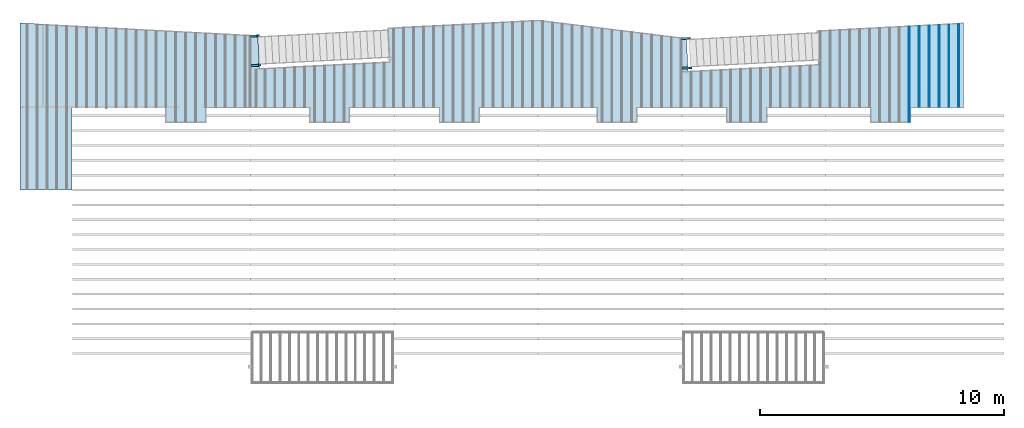
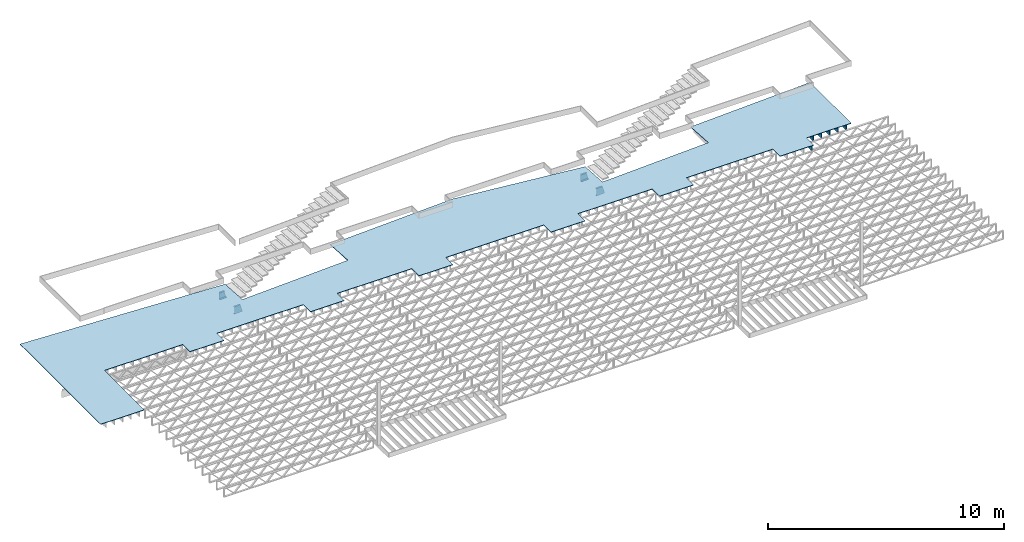
# One storey, part 13 of 23: 10 beams, 1 slab, 1 element without a shape of its own.
"""IFC4 building model written with IfcOpenShell, lengths in feet."""

from ifc_helpers import new_model, entity, si_unit, converted_unit, derived_unit, direction, frame, frame_2d, origin, origin_2d_with_axis, place, context, subcontext, project, spatial, polyline, circle_curve, parameter, trimmed, segment, composite_curve, rectangle, outline, extrude, clip, halfspace, source, transform, mapped, material, layer, layer_set, layer_usage, material_profile, profile_set, profile_usage, type_object, type_shapes, element, aggregate, save


model = new_model("IFC4")

# Units and contexts
model_context_1 = context("Model", 3, precision=0.0001, world=origin(), true_north=direction((6.12303176911189e-17, 1.0)))
model_context_2 = context("Model", 3, precision=0.0001, world=origin(), true_north=direction((6.12303176911189e-17, 1.0)))
body_context = subcontext(model_context_2, "Body", "Model", "MODEL_VIEW")
ifc_project = project(units=[converted_unit("LENGTHUNIT", "FOOT", entity("IfcRatioMeasure", 0.3048), si_unit("LENGTHUNIT", "METRE"), dimensions=[1, 0, 0, 0, 0, 0, 0]), converted_unit("AREAUNIT", "SQUARE FOOT", entity("IfcRatioMeasure", 0.09290304), si_unit("AREAUNIT", "SQUARE_METRE"), dimensions=[2, 0, 0, 0, 0, 0, 0]), converted_unit("VOLUMEUNIT", "CUBIC FOOT", entity("IfcRatioMeasure", 0.028316846592), si_unit("VOLUMEUNIT", "CUBIC_METRE"), dimensions=[3, 0, 0, 0, 0, 0, 0]), converted_unit("PLANEANGLEUNIT", "DEGREE", entity("IfcRatioMeasure", 0.0174532925199433), si_unit("PLANEANGLEUNIT", "RADIAN"), dimensions=[0, 0, 0, 0, 0, 0, 0]), si_unit("MASSUNIT", "GRAM", prefix="KILO"), derived_unit("MASSDENSITYUNIT", [(si_unit("MASSUNIT", "GRAM", prefix="KILO"), 1), (si_unit("LENGTHUNIT", "METRE"), -3)]), derived_unit("MOMENTOFINERTIAUNIT", [(si_unit("LENGTHUNIT", "METRE"), 4)]), si_unit("TIMEUNIT", "SECOND"), si_unit("FREQUENCYUNIT", "HERTZ"), si_unit("THERMODYNAMICTEMPERATUREUNIT", "DEGREE_CELSIUS"), derived_unit("THERMALTRANSMITTANCEUNIT", [(si_unit("MASSUNIT", "GRAM", prefix="KILO"), 1), (si_unit("THERMODYNAMICTEMPERATUREUNIT", "KELVIN"), -1), (si_unit("TIMEUNIT", "SECOND"), -3)]), derived_unit("VOLUMETRICFLOWRATEUNIT", [(si_unit("LENGTHUNIT", "METRE"), 3), (si_unit("TIMEUNIT", "SECOND"), -1)]), si_unit("ELECTRICCURRENTUNIT", "AMPERE"), si_unit("ELECTRICVOLTAGEUNIT", "VOLT"), si_unit("POWERUNIT", "WATT"), si_unit("FORCEUNIT", "NEWTON"), si_unit("ILLUMINANCEUNIT", "LUX"), si_unit("LUMINOUSFLUXUNIT", "LUMEN"), si_unit("LUMINOUSINTENSITYUNIT", "CANDELA"), derived_unit("USERDEFINED", [(si_unit("MASSUNIT", "GRAM", prefix="KILO"), -1), (si_unit("LENGTHUNIT", "METRE"), -2), (si_unit("TIMEUNIT", "SECOND"), 3), (si_unit("LUMINOUSFLUXUNIT", "LUMEN"), 1)]), derived_unit("LINEARVELOCITYUNIT", [(si_unit("LENGTHUNIT", "METRE"), 1), (si_unit("TIMEUNIT", "SECOND"), -1)]), si_unit("PRESSUREUNIT", "PASCAL"), derived_unit("USERDEFINED", [(si_unit("LENGTHUNIT", "METRE"), -2), (si_unit("MASSUNIT", "GRAM", prefix="KILO"), 1), (si_unit("TIMEUNIT", "SECOND"), -2)]), derived_unit("LINEARFORCEUNIT", [(si_unit("MASSUNIT", "GRAM", prefix="KILO"), 1), (si_unit("LENGTHUNIT", "METRE"), 1), (si_unit("TIMEUNIT", "SECOND"), -2), (si_unit("LENGTHUNIT", "METRE"), -1)]), derived_unit("PLANARFORCEUNIT", [(si_unit("MASSUNIT", "GRAM", prefix="KILO"), 1), (si_unit("LENGTHUNIT", "METRE"), 1), (si_unit("TIMEUNIT", "SECOND"), -2), (si_unit("LENGTHUNIT", "METRE"), -2)])], contexts=[model_context_1])

# Site, building, storey
site_placement = place(None, origin())
site = spatial("IfcSite", under=ifc_project, at=site_placement, CompositionType="ELEMENT")
building_placement = place(site_placement, origin())
building = spatial("IfcBuilding", under=site, at=building_placement, CompositionType="ELEMENT")
storey_placement = place(building_placement, frame((0.0, 0.0, 10.8020833333333)))
storey = spatial("IfcBuildingStorey", under=building, at=storey_placement, Name="2ND FLOOR", CompositionType="ELEMENT", Elevation=10.8020833333333)

# Assembly, beam
assembly_placement = place(storey_placement, origin())
assembly = element("IfcElementAssembly", 1, at=assembly_placement, inside=storey, Name="Structural Beam System:Structural Framing System", ObjectType="Structural Beam System:Structural Framing System", AssemblyPlace="NOTDEFINED", PredefinedType="BEAM_GRID")
ifc_material_1 = material(Category="Materials")
ifc_material_profile_1 = material_profile(ifc_material_1, rectangle(XDim=0.9375, YDim=0.125000000000011, at=origin_2d_with_axis()))
ifc_profile_set_1 = profile_set([ifc_material_profile_1])
ifc_profile_usage_1 = profile_usage(ifc_profile_set_1, cardinal=8)
beam_type_1 = type_object("IfcBeamType", PredefinedType="BEAM", material=ifc_profile_set_1)
shared_shape_1 = source(origin(), body_context, "Body", "SweptSolid", [
    extrude(rectangle(XDim=0.9375, YDim=0.125000000000011, at=origin_2d_with_axis()), frame((-5.50563608775167, 0.0, 0.0), z_axis=(1.0, 0.0, 0.0), x_axis=(0.0, 0.0, -1.0)), (0.0, 0.0, 1.0), 11.0112721755033),
])
type_shapes(beam_type_1, [shared_shape_1])
beam_1_placement = place(assembly_placement, frame((-149.133993818795, 964.544654780593, -0.729166666666744), z_axis=(0.0, 0.0, 1.0), x_axis=(0.0, 1.0, 0.0)))
beam_1 = element("IfcBeam", 2, at=beam_1_placement, type_object=beam_type_1, material=ifc_profile_usage_1, PredefinedType="BEAM", context=body_context, shape_type="MappedRepresentation", body=[
    mapped(shared_shape_1, transform((0.0, 0.0, 0.0), scale=1.0)),
])

# Beams
ifc_material_2 = material(Name="STEEL C CHANNEL - HDG - SEE STRUCT", Category="Materials")
ifc_material_profile_2 = material_profile(ifc_material_2, outline(composite_curve([segment(polyline([(-0.625000000000096, -0.136458333333336), (0.625000000000011, -0.136458333333336)]), True, "CONTINUOUS"), segment(polyline([(0.625000000000011, -0.136458333333336), (0.625000000000011, 0.14687499999997)]), True, "CONTINUOUS"), segment(trimmed(circle_curve(frame_2d((0.624999999999954, 0.0927083333333472), x_axis=(0.0, 1.0)), 0.054166666666607), [parameter(0.0)], [parameter(90.0000000000565)], True, "PARAMETER"), True, "CONTINUOUS"), segment(polyline([(0.570833333333347, 0.0927083333333473), (0.539816380436459, -0.1031250000001)]), True, "CONTINUOUS"), segment(polyline([(0.539816380436459, -0.103124999999986), (-0.539816380436541, -0.103124999999985)]), True, "CONTINUOUS"), segment(polyline([(-0.539816380436431, -0.103124999999985), (-0.570833333333319, 0.0927083333333486)]), True, "CONTINUOUS"), segment(trimmed(circle_curve(frame_2d((-0.624999999999922, 0.0927083333333487), x_axis=(1.0, 0.0)), 0.0541666666665973), [parameter(0.0)], [parameter(90.0000000001767)], True, "PARAMETER"), True, "CONTINUOUS"), segment(polyline([(-0.624999999999989, 0.14687499999997), (-0.624999999999986, -0.136458333333336)]), True, "CONTINUOUS")], self_intersect=False)), Name="C15x33.9, TYP. STRINGER")
ifc_profile_set_2 = profile_set([ifc_material_profile_2], Name="C15x33.9, TYP. STRINGER")
ifc_profile_usage_2 = profile_usage(ifc_profile_set_2, cardinal=8)
beam_type_2 = type_object("IfcBeamType", Name="C-Channel:C15x33.9, TYP. STRINGER", PredefinedType="BEAM", material=ifc_profile_set_2)
shared_shape_2 = source(origin(), body_context, "Body", "Clipping", [
    clip(extrude(outline(composite_curve([segment(polyline([(-0.146875000000084, -0.624999999999993), (0.136458333333448, -0.624999999999993)]), True, "CONTINUOUS"), segment(polyline([(0.13645833333322, -0.625000000000076), (0.136458333333333, 0.625000000000007)]), True, "CONTINUOUS"), segment(polyline([(0.136458333333448, 0.625000000000007), (-0.146874999999971, 0.625000000000007)]), True, "CONTINUOUS"), segment(trimmed(circle_curve(frame_2d((-0.0927083333334615, 0.624999999999929), x_axis=(-1.0, 0.0)), 0.0541666666665845), [parameter(0.0)], [parameter(90.0000000002029)], True, "PARAMETER"), True, "CONTINUOUS"), segment(polyline([(-0.0927083333334615, 0.570833333333338), (0.103124999999984, 0.539816380436438)]), True, "CONTINUOUS"), segment(polyline([(0.10312499999987, 0.539816380436449), (0.10312499999987, -0.539816380436518)]), True, "CONTINUOUS"), segment(polyline([(0.103125000000098, -0.539816380436406), (-0.0927083333334615, -0.570833333333331)]), True, "CONTINUOUS"), segment(trimmed(circle_curve(frame_2d((-0.092708333333575, -0.62499999999987), x_axis=(0.0, 1.0)), 0.0541666666665441), [parameter(0.0)], [parameter(90.0000000005389)], True, "PARAMETER"), True, "CONTINUOUS")], self_intersect=False)), frame((-241.721090693233, 964.591043315299, 8.97916666666633), z_axis=(0.99862953475458, 0.0523359562428374, 0.0), x_axis=(0.0523359562428374, -0.99862953475458, 0.0)), (0.0, 0.0, 1.0), 1.35148027803678), halfspace(frame((-240.034458951307, 965.538675935652, 6.99303841413297), z_axis=(0.961401963826961, 0.0503849419223695, 0.270495141503766), x_axis=(0.270124437313279, 0.0141566218896707, -0.962721339964404)), False)),
])
type_shapes(beam_type_2, [shared_shape_2])
beam_2_placement = place(storey_placement, frame((0.0, 0.0, -10.8020833333333)))
element("IfcBeam", 3, at=beam_2_placement, inside=storey, type_object=beam_type_2, material=ifc_profile_usage_2, Name="C-Channel:C15x33.9, TYP. STRINGER", ObjectType="C-Channel:C15x33.9, TYP. STRINGER", PredefinedType="BEAM", context=body_context, shape_type="MappedRepresentation", body=[
    mapped(shared_shape_2, transform((0.0, 0.0, 0.0), scale=1.0)),
])
ifc_profile_usage_3 = profile_usage(ifc_profile_set_2, cardinal=8)
beam_type_3 = type_object("IfcBeamType", Name="C-Channel:C15x33.9, TYP. STRINGER", PredefinedType="BEAM", material=ifc_profile_set_2)
shared_shape_3 = source(origin(), body_context, "Body", "Clipping", [
    clip(clip(extrude(outline(composite_curve([segment(polyline([(-0.625000000000227, -0.136458333333221), (0.625000000000027, -0.136458333333221)]), True, "CONTINUOUS"), segment(polyline([(0.625000000000027, -0.136458333333221), (0.625000000000027, 0.146875000000426)]), True, "CONTINUOUS"), segment(trimmed(circle_curve(frame_2d((0.624999999999968, 0.0927083333334622), x_axis=(0.0, 1.0)), 0.0541666666666086), [parameter(0.0)], [parameter(90.0000000000584)], True, "PARAMETER"), True, "CONTINUOUS"), segment(polyline([(0.570833333333399, 0.0927083333336894), (0.539816380436473, -0.103124999999871)]), True, "CONTINUOUS"), segment(polyline([(0.539816380436475, -0.103124999999871), (-0.539816380436669, -0.10312499999987)]), True, "CONTINUOUS"), segment(polyline([(-0.539816380436415, -0.10312499999987), (-0.570833333333322, 0.0927083333335772)]), True, "CONTINUOUS"), segment(trimmed(circle_curve(frame_2d((-0.62499999999992, 0.0927083333334637), x_axis=(1.0, 0.0)), 0.0541666666666016), [parameter(0.0)], [parameter(90.0000000003082)], True, "PARAMETER"), True, "CONTINUOUS"), segment(polyline([(-0.624999999999973, 0.1468750000002), (-0.624999999999973, -0.136458333333221)]), True, "CONTINUOUS")], self_intersect=False)), frame((-241.745847329124, 968.572287142718, 8.97916666667323), z_axis=(0.998629534754581, 0.0523359562428164, 0.0), x_axis=(0.0, 0.0, 1.0)), (0.0, 0.0, 1.0), 1.16784078307327), halfspace(frame((-241.738160485591, 933.741866098016, 4.0), z_axis=(-1.0, 0.0, 0.0), x_axis=(0.0, -1.0, 0.0)), False)), halfspace(frame((-240.034458951307, 965.538675935652, 6.99303841413297), z_axis=(0.961401963826961, 0.0503849419223695, 0.270495141503766), x_axis=(0.270124437313279, 0.0141566218896707, -0.962721339964404)), False)),
])
type_shapes(beam_type_3, [shared_shape_3])
beam_3_placement = place(storey_placement, frame((0.0, 0.0, -10.8020833333333)))
element("IfcBeam", 4, at=beam_3_placement, inside=storey, type_object=beam_type_3, material=ifc_profile_usage_3, Name="C-Channel:C15x33.9, TYP. STRINGER", ObjectType="C-Channel:C15x33.9, TYP. STRINGER", PredefinedType="BEAM", context=body_context, shape_type="MappedRepresentation", body=[
    mapped(shared_shape_3, transform((0.0, 0.0, 0.0), scale=1.0)),
])
ifc_profile_usage_4 = profile_usage(ifc_profile_set_2, cardinal=8)
beam_type_4 = type_object("IfcBeamType", Name="C-Channel:C15x33.9, TYP. STRINGER", PredefinedType="BEAM", material=ifc_profile_set_2)
shared_shape_4 = source(origin(), body_context, "Body", "Clipping", [
    clip(extrude(outline(composite_curve([segment(polyline([(-0.146875000000083, -0.624999999999993), (0.13645833333345, -0.624999999999993)]), True, "CONTINUOUS"), segment(polyline([(0.136458333333221, -0.625000000000069), (0.136458333333221, 0.625000000000007)]), True, "CONTINUOUS"), segment(polyline([(0.13645833333345, 0.625000000000007), (-0.146875000000083, 0.625000000000007)]), True, "CONTINUOUS"), segment(trimmed(circle_curve(frame_2d((-0.09270833333346, 0.624999999999929), x_axis=(-1.0, 0.0)), 0.0541666666665845), [parameter(0.0)], [parameter(90.0000000002029)], True, "PARAMETER"), True, "CONTINUOUS"), segment(polyline([(-0.09270833333346, 0.570833333333338), (0.103125000000099, 0.539816380436422)]), True, "CONTINUOUS"), segment(polyline([(0.103124999999872, 0.539816380436449), (0.103124999999872, -0.539816380436518)]), True, "CONTINUOUS"), segment(polyline([(0.103125000000099, -0.539816380436406), (-0.09270833333346, -0.570833333333329)]), True, "CONTINUOUS"), segment(trimmed(circle_curve(frame_2d((-0.0927083333335735, -0.62499999999987), x_axis=(0.0, 1.0)), 0.0541666666665439), [parameter(0.0)], [parameter(90.0000000005408)], True, "PARAMETER"), True, "CONTINUOUS")], self_intersect=False)), frame((-183.721090693233, 964.243642603455, 8.97916666665938), z_axis=(0.99862953475458, 0.0523359562428374, 0.0), x_axis=(0.0523359562428374, -0.99862953475458, 0.0)), (0.0, 0.0, 1.0), 1.35148027803877), halfspace(frame((-182.034458951307, 965.191275223808, 6.99303841413298), z_axis=(0.961401963826961, 0.0503849419223695, 0.270495141503766), x_axis=(0.270124437313279, 0.0141566218896707, -0.962721339964404)), False)),
])
type_shapes(beam_type_4, [shared_shape_4])
beam_4_placement = place(storey_placement, frame((0.0, 0.0, -10.8020833333333)))
element("IfcBeam", 5, at=beam_4_placement, inside=storey, type_object=beam_type_4, material=ifc_profile_usage_4, Name="C-Channel:C15x33.9, TYP. STRINGER", ObjectType="C-Channel:C15x33.9, TYP. STRINGER", PredefinedType="BEAM", context=body_context, shape_type="MappedRepresentation", body=[
    mapped(shared_shape_4, transform((0.0, 0.0, 0.0), scale=1.0)),
])
ifc_profile_usage_5 = profile_usage(ifc_profile_set_2, cardinal=8)
beam_type_5 = type_object("IfcBeamType", Name="C-Channel:C15x33.9, TYP. STRINGER", PredefinedType="BEAM", material=ifc_profile_set_2)
shared_shape_5 = source(origin(), body_context, "Body", "Clipping", [
    clip(extrude(outline(composite_curve([segment(polyline([(-0.625000000000226, -0.13645833333345), (0.625000000000028, -0.13645833333345)]), True, "CONTINUOUS"), segment(polyline([(0.625000000000028, -0.13645833333345), (0.625000000000028, 0.146875000000198)]), True, "CONTINUOUS"), segment(trimmed(circle_curve(frame_2d((0.62499999999997, 0.0927083333332329), x_axis=(0.0, 1.0)), 0.054166666666608), [parameter(0.0)], [parameter(90.0000000000584)], True, "PARAMETER"), True, "CONTINUOUS"), segment(polyline([(0.5708333333334, 0.0927083333334615), (0.539816380436475, -0.103125000000099)]), True, "CONTINUOUS"), segment(polyline([(0.539816380436477, -0.103125000000099), (-0.539816380436667, -0.103125000000101)]), True, "CONTINUOUS"), segment(polyline([(-0.539816380436413, -0.103125000000101), (-0.57083333333332, 0.0927083333333465)]), True, "CONTINUOUS"), segment(trimmed(circle_curve(frame_2d((-0.624999999999917, 0.0927083333332329), x_axis=(1.0, 0.0)), 0.0541666666665999), [parameter(0.0)], [parameter(90.0000000003101)], True, "PARAMETER"), True, "CONTINUOUS"), segment(polyline([(-0.624999999999972, 0.146874999999969), (-0.624999999999972, -0.13645833333345)]), True, "CONTINUOUS")], self_intersect=False)), frame((-183.827402830635, 968.220612288151, 8.97916666667324), z_axis=(0.998629534754575, 0.0523359562429165, 0.0), x_axis=(0.0, 0.0, 1.0)), (0.0, 0.0, 1.0), 1.24950820695101), halfspace(frame((-182.034458951307, 965.191275223808, 6.99303841413298), z_axis=(0.961401963826961, 0.0503849419223695, 0.270495141503766), x_axis=(0.270124437313279, 0.0141566218896707, -0.962721339964404)), False)),
])
type_shapes(beam_type_5, [shared_shape_5])
beam_5_placement = place(storey_placement, frame((0.0, 0.0, -10.8020833333333)))
element("IfcBeam", 6, at=beam_5_placement, inside=storey, type_object=beam_type_5, material=ifc_profile_usage_5, Name="C-Channel:C15x33.9, TYP. STRINGER", ObjectType="C-Channel:C15x33.9, TYP. STRINGER", PredefinedType="BEAM", context=body_context, shape_type="MappedRepresentation", body=[
    mapped(shared_shape_5, transform((0.0, 0.0, 0.0), scale=1.0)),
])

# Beam
ifc_profile_usage_6 = profile_usage(ifc_profile_set_1, cardinal=8)
beam_type_6 = type_object("IfcBeamType", PredefinedType="BEAM", material=ifc_profile_set_1)
shared_shape_6 = source(origin(), body_context, "Body", "SweptSolid", [
    extrude(rectangle(XDim=0.9375, YDim=0.125000000000011, at=origin_2d_with_axis()), frame((-6.40602910094731, 0.0, 0.0), z_axis=(1.0, 0.0, 0.0), x_axis=(0.0, 0.0, -1.0)), (0.0, 0.0, 1.0), 12.8120582018946),
])
type_shapes(beam_type_6, [shared_shape_6])
beam_6_placement = place(assembly_placement, frame((-153.133993818795, 963.434630650265, -0.729166666666744), z_axis=(0.0, 0.0, 1.0), x_axis=(0.0, 1.0, 0.0)))
beam_6 = element("IfcBeam", 7, at=beam_6_placement, type_object=beam_type_6, material=ifc_profile_usage_6, PredefinedType="BEAM", context=body_context, shape_type="MappedRepresentation", body=[
    mapped(shared_shape_6, transform((0.0, 0.0, 0.0), scale=1.0)),
])

ifc_profile_usage_7 = profile_usage(ifc_profile_set_1, cardinal=8)
beam_type_7 = type_object("IfcBeamType", PredefinedType="BEAM", material=ifc_profile_set_1)
shared_shape_7 = source(origin(), body_context, "Body", "SweptSolid", [
    extrude(rectangle(XDim=0.9375, YDim=0.125000000000011, at=origin_2d_with_axis()), frame((-5.43575938370998, 0.0, 0.0), z_axis=(1.0, 0.0, 0.0), x_axis=(0.0, 0.0, -1.0)), (0.0, 0.0, 1.0), 10.87151876742),
])
type_shapes(beam_type_7, [shared_shape_7])
beam_7_placement = place(assembly_placement, frame((-151.800660485462, 964.474777406546, -0.729166666666744), z_axis=(0.0, 0.0, 1.0), x_axis=(0.0, 1.0, 0.0)))
beam_7 = element("IfcBeam", 8, at=beam_7_placement, type_object=beam_type_7, material=ifc_profile_usage_7, PredefinedType="BEAM", context=body_context, shape_type="MappedRepresentation", body=[
    mapped(shared_shape_7, transform((0.0, 0.0, 0.0), scale=1.0)),
])

ifc_profile_usage_8 = profile_usage(ifc_profile_set_1, cardinal=8)
beam_type_8 = type_object("IfcBeamType", PredefinedType="BEAM", material=ifc_profile_set_1)
shared_shape_8 = source(origin(), body_context, "Body", "SweptSolid", [
    extrude(rectangle(XDim=0.9375, YDim=0.125000000000011, at=origin_2d_with_axis()), frame((-5.47069773573082, 0.0, 0.0), z_axis=(1.0, 0.0, 0.0), x_axis=(0.0, 0.0, -1.0)), (0.0, 0.0, 1.0), 10.9413954714616),
])
type_shapes(beam_type_8, [shared_shape_8])
beam_8_placement = place(assembly_placement, frame((-150.467327152129, 964.50971609357, -0.729166666666744), z_axis=(0.0, 0.0, 1.0), x_axis=(0.0, 1.0, 0.0)))
beam_8 = element("IfcBeam", 9, at=beam_8_placement, type_object=beam_type_8, material=ifc_profile_usage_8, PredefinedType="BEAM", context=body_context, shape_type="MappedRepresentation", body=[
    mapped(shared_shape_8, transform((0.0, 0.0, 0.0), scale=1.0)),
])

ifc_profile_usage_9 = profile_usage(ifc_profile_set_1, cardinal=8)
beam_type_9 = type_object("IfcBeamType", PredefinedType="BEAM", material=ifc_profile_set_1)
shared_shape_9 = source(origin(), body_context, "Body", "SweptSolid", [
    extrude(rectangle(XDim=0.9375, YDim=0.125000000000011, at=origin_2d_with_axis()), frame((-5.54057443977251, 0.0, 0.0), z_axis=(1.0, 0.0, 0.0), x_axis=(0.0, 0.0, -1.0)), (0.0, 0.0, 1.0), 11.081148879545),
])
type_shapes(beam_type_9, [shared_shape_9])
beam_9_placement = place(assembly_placement, frame((-147.800660485462, 964.579593467616, -0.729166666666744), z_axis=(0.0, 0.0, 1.0), x_axis=(0.0, 1.0, 0.0)))
beam_9 = element("IfcBeam", 10, at=beam_9_placement, type_object=beam_type_9, material=ifc_profile_usage_9, PredefinedType="BEAM", context=body_context, shape_type="MappedRepresentation", body=[
    mapped(shared_shape_9, transform((0.0, 0.0, 0.0), scale=1.0)),
])

ifc_profile_usage_10 = profile_usage(ifc_profile_set_1, cardinal=8)
beam_type_10 = type_object("IfcBeamType", PredefinedType="BEAM", material=ifc_profile_set_1)
shared_shape_10 = source(origin(), body_context, "Body", "SweptSolid", [
    extrude(rectangle(XDim=0.9375, YDim=0.125000000000011, at=origin_2d_with_axis()), frame((-5.57551279179336, 0.0, 0.0), z_axis=(1.0, 0.0, 0.0), x_axis=(0.0, 0.0, -1.0)), (0.0, 0.0, 1.0), 11.1510255835867),
])
type_shapes(beam_type_10, [shared_shape_10])
beam_10_placement = place(assembly_placement, frame((-146.467327152129, 964.614532154639, -0.729166666666744), z_axis=(0.0, 0.0, 1.0), x_axis=(0.0, 1.0, 0.0)))
beam_10 = element("IfcBeam", 11, at=beam_10_placement, type_object=beam_type_10, material=ifc_profile_usage_10, PredefinedType="BEAM", context=body_context, shape_type="MappedRepresentation", body=[
    mapped(shared_shape_10, transform((0.0, 0.0, 0.0), scale=1.0)),
])

aggregate(assembly, [beam_1, beam_6, beam_7, beam_8, beam_9, beam_10])

# Slab
ifc_material_3 = material(Name="COMPOSITE DECKING", Category="Materials")
ifc_layer = layer(ifc_material_3, 0.0833333333333333, Name="COMPOSITE DECKING", Category="Materials")
ifc_layer_set = layer_set([ifc_layer], Name="Floor:floor")
ifc_layer_usage = layer_usage(ifc_layer_set, "AXIS3", "POSITIVE", 0.0)
slab_type = type_object("IfcSlabType", Name="Floor:floor", PredefinedType="FLOOR", material=ifc_layer_set)
slab_placement = place(storey_placement, origin())
element("IfcSlab", 12, at=slab_placement, inside=storey, type_object=slab_type, material=ifc_layer_usage, Name="Floor:floor", ObjectType="Floor:floor", PredefinedType="FLOOR", context=body_context, shape_type="SweptSolid", body=[
    extrude(outline(polyline([(-12.3582820269273, -65.8429906871204), (10.1145888440207, -65.8429906871204), (8.43819556529411, -33.8555013933543), (4.00340490843701, -33.6230838634432), (4.91877599891848, -16.1567629659345), (9.45421852244135, -16.394455436658), (10.5155528171952, 3.85700931292644), (8.0662864339871, 23.8046832321653), (3.63817692845862, 24.0367506177719), (4.55623682755117, 41.5543770399257), (9.09167929991963, 41.3166845718827), (10.1305931968635, 61.1403426462533), (-1.30619737609095, 61.1403426462533), (-1.30619917463468, 53.982009284716), (-3.31661536026036, 53.982009284716), (-3.31661536026036, 48.5236759513827), (-1.31661257058704, 48.5236759513827), (-1.31661605539693, 34.6538823976193), (-3.31661536026036, 34.6538829001229), (-3.31661536026036, 29.1903421243623), (-1.31661479650597, 29.1903425871669), (-1.31661201967938, 17.1903429668514), (-3.31661536026058, 17.1903429668514), (-3.31661536026058, 11.7268024224931), (-1.31661210079824, 11.7268029249977), (-1.31661605539693, -4.01278429915214), (-3.31661536026047, -4.01278379664859), (-3.31661536026047, -9.47632457240917), (-1.31661479650597, -9.47632410960463), (-1.31661201967995, -21.4763214849587), (-3.31661536026058, -21.4763214849587), (-3.31661536026058, -26.9398642441736), (-1.31661273991233, -26.9398637416692), (-1.31661273991233, -40.8096562762393), (-3.31661536026058, -40.8096562762393), (-3.31661536026058, -46.2679906870777), (-1.31661584130131, -46.2679906870777), (-1.31661267971845, -58.851316302527), (-12.3582820269273, -58.8513188334747), (-12.3582820269273, -65.8429906871204)])), frame((-206.928503131784, 960.220216909578, -0.177083333333204), z_axis=(0.0, 0.0, -1.0), x_axis=(0.0, 1.0, 0.0)), (0.0, 0.0, 1.0), 0.0833333333333339),
])

save(model, "model.ifc")
